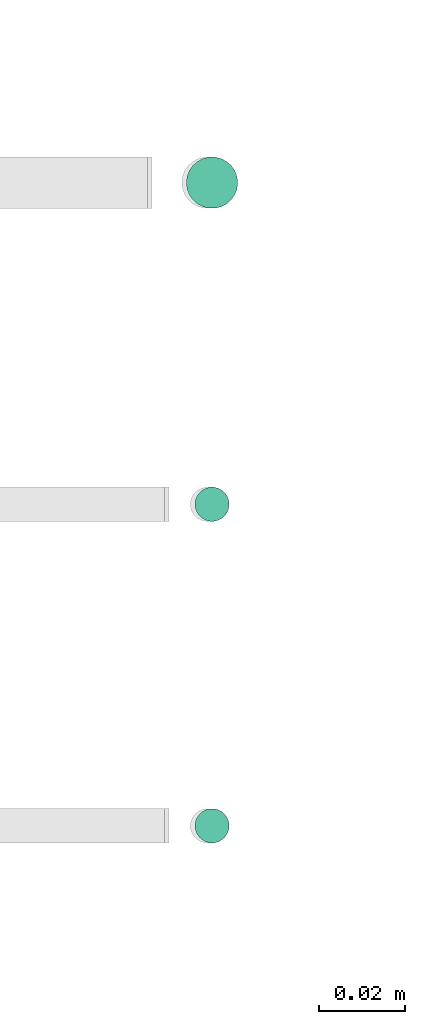
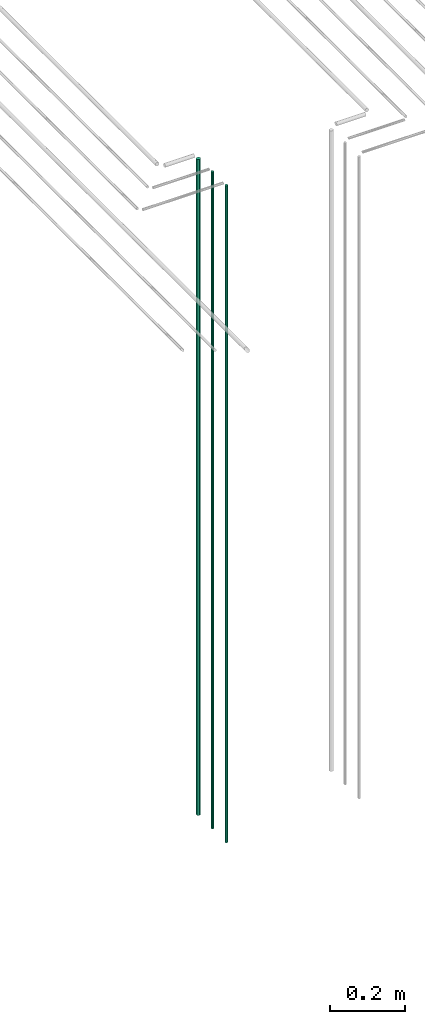
# One storey, part 50 of 331: 3 flow segments.
"""IFC2X3 building model written with IfcOpenShell, lengths in millimetres."""

from ifc_helpers import new_model, entity, si_unit, converted_unit, derived_unit, direction, frame, origin, origin_2d_with_axis, place, context, subcontext, project, spatial, circle, extrude, type_object, element, save


model = new_model("IFC2X3")

# Units and contexts
model_context = context("Model", 3, precision=0.01, world=origin(), true_north=direction((6.12303176911189e-17, 1.0)))
body_context = subcontext(model_context, "Body", "Model", "MODEL_VIEW")
ifc_project = project(units=[si_unit("LENGTHUNIT", "METRE", prefix="MILLI"), si_unit("AREAUNIT", "SQUARE_METRE"), si_unit("VOLUMEUNIT", "CUBIC_METRE"), converted_unit("PLANEANGLEUNIT", "DEGREE", entity("IfcRatioMeasure", 0.0174532925199433), si_unit("PLANEANGLEUNIT", "RADIAN"), dimensions=[0, 0, 0, 0, 0, 0, 0]), si_unit("MASSUNIT", "GRAM", prefix="KILO"), derived_unit("MASSDENSITYUNIT", [(si_unit("MASSUNIT", "GRAM", prefix="KILO"), 1), (si_unit("LENGTHUNIT", "METRE"), -3)]), derived_unit("MOMENTOFINERTIAUNIT", [(si_unit("LENGTHUNIT", "METRE"), 4)]), si_unit("TIMEUNIT", "SECOND"), si_unit("FREQUENCYUNIT", "HERTZ"), si_unit("THERMODYNAMICTEMPERATUREUNIT", "DEGREE_CELSIUS"), derived_unit("THERMALTRANSMITTANCEUNIT", [(si_unit("MASSUNIT", "GRAM", prefix="KILO"), 1), (si_unit("THERMODYNAMICTEMPERATUREUNIT", "KELVIN"), -1), (si_unit("TIMEUNIT", "SECOND"), -3)]), derived_unit("VOLUMETRICFLOWRATEUNIT", [(si_unit("LENGTHUNIT", "METRE"), 3), (si_unit("TIMEUNIT", "SECOND"), -1)]), derived_unit("MASSFLOWRATEUNIT", [(si_unit("MASSUNIT", "GRAM", prefix="KILO"), 1), (si_unit("TIMEUNIT", "SECOND"), -1)]), derived_unit("ROTATIONALFREQUENCYUNIT", [(si_unit("TIMEUNIT", "SECOND"), -1)]), si_unit("ELECTRICCURRENTUNIT", "AMPERE"), si_unit("ELECTRICVOLTAGEUNIT", "VOLT"), si_unit("POWERUNIT", "WATT"), si_unit("FORCEUNIT", "NEWTON", prefix="KILO"), si_unit("ILLUMINANCEUNIT", "LUX"), si_unit("LUMINOUSFLUXUNIT", "LUMEN"), si_unit("LUMINOUSINTENSITYUNIT", "CANDELA"), derived_unit("USERDEFINED", [(si_unit("MASSUNIT", "GRAM", prefix="KILO"), -1), (si_unit("LENGTHUNIT", "METRE"), -2), (si_unit("TIMEUNIT", "SECOND"), 3), (si_unit("LUMINOUSFLUXUNIT", "LUMEN"), 1)]), derived_unit("LINEARVELOCITYUNIT", [(si_unit("LENGTHUNIT", "METRE"), 1), (si_unit("TIMEUNIT", "SECOND"), -1)]), si_unit("PRESSUREUNIT", "PASCAL"), derived_unit("USERDEFINED", [(si_unit("LENGTHUNIT", "METRE"), -2), (si_unit("MASSUNIT", "GRAM", prefix="KILO"), 1), (si_unit("TIMEUNIT", "SECOND"), -2)]), derived_unit("LINEARFORCEUNIT", [(si_unit("MASSUNIT", "GRAM", prefix="KILO"), 1), (si_unit("LENGTHUNIT", "METRE"), 1), (si_unit("TIMEUNIT", "SECOND"), -2), (si_unit("LENGTHUNIT", "METRE"), -1)]), derived_unit("PLANARFORCEUNIT", [(si_unit("MASSUNIT", "GRAM", prefix="KILO"), 1), (si_unit("LENGTHUNIT", "METRE"), 1), (si_unit("TIMEUNIT", "SECOND"), -2), (si_unit("LENGTHUNIT", "METRE"), -2)])], contexts=[model_context])

# Site, building, storey
site_placement = place(None, frame((0.0, -0.00077364408347762, 0.0)))
site = spatial("IfcSite", under=ifc_project, at=site_placement, CompositionType="ELEMENT")
building_placement = place(site_placement, origin())
building = spatial("IfcBuilding", under=site, at=building_placement, CompositionType="ELEMENT")
storey_placement = place(building_placement, origin())
storey = spatial("IfcBuildingStorey", under=building, at=storey_placement, CompositionType="ELEMENT", Elevation=0.0)

# Flow segments
pipe_segment_type = type_object("IfcPipeSegmentType", PredefinedType="NOTDEFINED")
flow_segment_placement = place(storey_placement, frame((43957.8885868351, 3883.89349484352, 12990.0)))
element("IfcFlowSegment", 1, at=flow_segment_placement, inside=storey, type_object=pipe_segment_type, context=body_context, shape_type="SweptSolid", body=[
    extrude(circle(Radius=6.0, at=origin_2d_with_axis()), frame((7.59527223591454, 7.59527223591616, 0.0)), (0.0, 0.0, 1.0), 2146.0),
])
for number, where in (
    (2, (43959.8885868351, 3735.89349484338, 12990.0)),
    (3, (43959.8885868351, 3810.89349484379, 12990.0)),
):
    element("IfcFlowSegment", number, at=place(storey_placement, frame(where)), inside=storey, type_object=pipe_segment_type, context=body_context, shape_type="SweptSolid", body=[
        extrude(circle(Radius=4.0, at=origin_2d_with_axis()), frame((5.59527223591499, 5.59527223591607, 0.0)), (0.0, 0.0, 1.0), 2150.00000000001),
    ])

save(model, "model.ifc")
